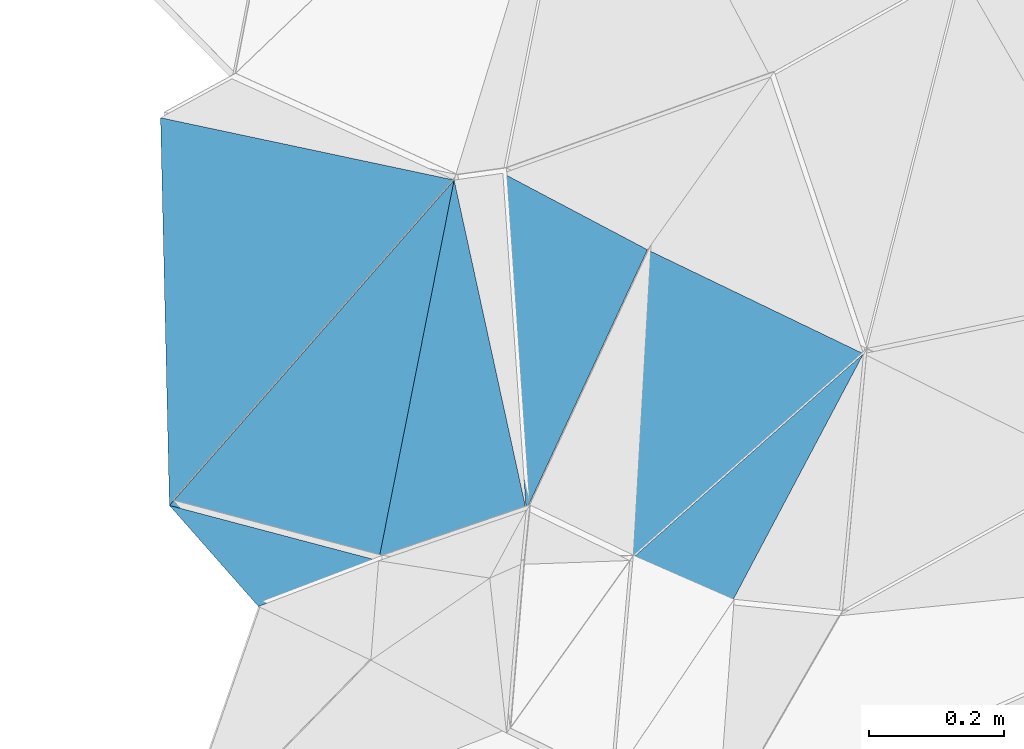
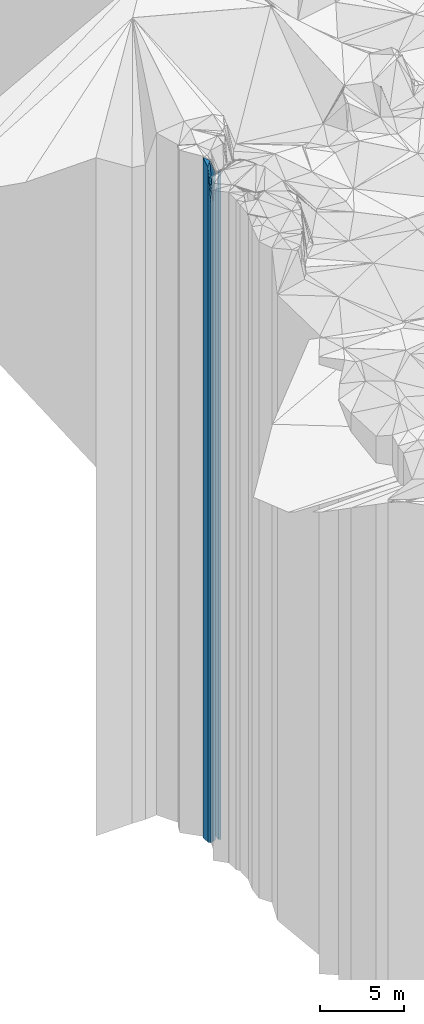
# One storey, part 230 of 275: 7 plates.
"""IFC2X3 building model written with IfcOpenShell, lengths in millimetres."""

import ifcopenshell
import ifcopenshell.guid

model = None  # the IFC model being written
_history = None  # IfcOwnerHistory: only IFC2X3 demands one
_inside = {}  # id of a spatial element -> (the spatial element, [elements in it])
_under = {}  # id of a project, library or spatial element -> (it, [spatial elements below it])
_declared = {}  # id of a project -> (the project, [libraries it declares])
_typed = {}  # id of a type object -> (the type object, [elements of that type])
_made_of = {}  # id of a material, layer set ... -> (it, [elements and type objects made of it])


def new_model(schema):
    """Start an empty IFC model of exactly this schema.

    Asked for "IFC4X3", IfcOpenShell would pick the latest addendum, in which some entities
    have other attributes; the version numbers below select the first issue.
    IFC2X3 requires an IfcOwnerHistory on every rooted entity: one is made here for all.
    """
    global model, _history
    if schema == "IFC4X3":
        model = ifcopenshell.file(schema_version=(4, 3, 0, 0))
    else:
        model = ifcopenshell.file(schema=schema)
    _inside.clear()
    _under.clear()
    _declared.clear()
    _typed.clear()
    _made_of.clear()
    _history = None
    if model.schema == "IFC2X3":
        org = make("IfcOrganization", Name="unknown")
        user = make(
            "IfcPersonAndOrganization",
            ThePerson=make("IfcPerson", FamilyName="unknown"),
            TheOrganization=org,
        )
        app = make(
            "IfcApplication",
            ApplicationDeveloper=org,
            Version="unknown",
            ApplicationFullName="unknown",
            ApplicationIdentifier="unknown",
        )
        _history = make(
            "IfcOwnerHistory",
            OwningUser=user,
            OwningApplication=app,
            ChangeAction="ADDED",
            CreationDate=0,
        )
    return model


def make(cls, **values):
    """One entity of the class cls with the attributes given. An attribute that is None is left unset."""
    return model.create_entity(
        cls, **{name: value for name, value in values.items() if value is not None}
    )


def rooted(cls, **values):
    """An entity with a GlobalId (a new one), such as an element, a storey or a relation."""
    return make(cls, GlobalId=ifcopenshell.guid.new(), OwnerHistory=_history, **values)


def si_unit(unit_type, name, prefix=None):
    """IfcSIUnit, for example si_unit("LENGTHUNIT", "METRE", prefix="MILLI")."""
    return make("IfcSIUnit", UnitType=unit_type, Prefix=prefix, Name=name)


def assignment(units):
    """IfcUnitAssignment: the units of a project."""
    return None if units is None else make("IfcUnitAssignment", Units=units)


def point(xyz):
    """IfcCartesianPoint."""
    return None if xyz is None else make("IfcCartesianPoint", Coordinates=xyz)


def direction(xyz):
    """IfcDirection."""
    return None if xyz is None else make("IfcDirection", DirectionRatios=xyz)


def frame(location, z_axis=None, x_axis=None):
    """IfcAxis2Placement3D, a coordinate frame: its origin and axes. An axis left out is left unset."""
    return make(
        "IfcAxis2Placement3D",
        Location=point(location),
        Axis=direction(z_axis),
        RefDirection=direction(x_axis),
    )


def origin_with_axes():
    """The frame at (0, 0, 0) with the z axis (0, 0, 1) and the x axis (1, 0, 0) written out."""
    return frame((0.0, 0.0, 0.0), z_axis=(0.0, 0.0, 1.0), x_axis=(1.0, 0.0, 0.0))


def place(relative_to, where):
    """IfcLocalPlacement: puts the frame where relative to a parent placement (None: the world)."""
    return make(
        "IfcLocalPlacement", PlacementRelTo=relative_to, RelativePlacement=where
    )


def context(
    kind, dimensions, precision=None, world=None, true_north=None, identifier=None
):
    """IfcGeometricRepresentationContext, for example the 3D "Model" context."""
    return make(
        "IfcGeometricRepresentationContext",
        ContextIdentifier=identifier,
        ContextType=kind,
        CoordinateSpaceDimension=dimensions,
        Precision=precision,
        WorldCoordinateSystem=world,
        TrueNorth=true_north,
    )


def subcontext(parent, identifier, kind, view, scale=None):
    """IfcGeometricRepresentationSubContext, for example "Body" below "Model"."""
    return make(
        "IfcGeometricRepresentationSubContext",
        ContextIdentifier=identifier,
        ContextType=kind,
        ParentContext=parent,
        TargetScale=scale,
        TargetView=view,
    )


def project(units=None, contexts=None):
    """IfcProject with its units and contexts."""
    return rooted(
        "IfcProject",
        Name="project",
        RepresentationContexts=contexts,
        UnitsInContext=assignment(units),
    )


def spatial(cls, under=None, at=None, **own):
    """A site, building, storey or space (cls), placed at a placement, below another one or the project."""
    s = rooted(cls, ObjectPlacement=at, **own)
    if under is not None:
        _under.setdefault(under.id(), (under, []))[1].append(s)
    return s


def faces_of(points, faces, orient=None, outer=None):
    """IfcFace entities. A face is a list of loops; a loop is a list of indices into points, from 0.

    orient and outer hold one flag for each loop. By default every Orientation is true, the
    first loop of a face is its IfcFaceOuterBound and the others are IfcFaceBound.
    """
    made = []
    for i, loops in enumerate(faces):
        bounds = []
        for j, loop in enumerate(loops):
            is_outer = j == 0 if outer is None else outer[i][j]
            bounds.append(
                make(
                    "IfcFaceOuterBound" if is_outer else "IfcFaceBound",
                    Bound=make("IfcPolyLoop", Polygon=[points[k] for k in loop]),
                    Orientation=True if orient is None else orient[i][j],
                )
            )
        made.append(make("IfcFace", Bounds=bounds))
    return made


def faceted_brep(points, faces, orient=None, outer=None, voids=None):
    """IfcFacetedBrep: a solid bounded by flat faces; with voids (closed shells), ...WithVoids."""
    shared = [point(p) for p in points]
    hull = make("IfcClosedShell", CfsFaces=faces_of(shared, faces, orient, outer))
    if voids is None:
        return make("IfcFacetedBrep", Outer=hull)
    return make(
        "IfcFacetedBrepWithVoids",
        Outer=hull,
        Voids=[
            make(cls, CfsFaces=faces_of(shared, fs, o, b)) for cls, fs, o, b in voids
        ],
    )


def shape(context_of_items, identifier, shape_type, items):
    """IfcShapeRepresentation: the items that make up one representation, for example the "Body"."""
    return make(
        "IfcShapeRepresentation",
        ContextOfItems=context_of_items,
        RepresentationIdentifier=identifier,
        RepresentationType=shape_type,
        Items=items,
    )


def material(Name=None, Category=None):
    """IfcMaterial."""
    return make("IfcMaterial", Name=Name, Category=Category)


def made_of(thing, what):
    """Note that an element or type object is made of a material, layer set ...; save() writes the relation."""
    if what is not None:
        _made_of.setdefault(what.id(), (what, []))[1].append(thing)
    return thing


def type_object(cls, material=None, **own):
    """A type object (cls), such as IfcWallType, which elements share."""
    return made_of(rooted(cls, **own), material)


def element(
    cls,
    number,
    at=None,
    inside=None,
    cuts=None,
    type_object=None,
    material=None,
    context=None,
    identifier="Body",
    shape_type=None,
    held_by="IfcProductDefinitionShape",
    body=None,
    shapes=None,
    **own,
):
    """One element of the class cls, such as IfcWall. Its Tag is "e" and its number.

    at: its placement. inside: the storey or other place that contains it. cuts: it is an
    opening in that element (IfcRelVoidsElement). A single representation is given by context,
    identifier, shape_type and body (its items); several are given by shapes. held_by: the class
    of the entity that holds the representations. save() writes the other relations.
    """
    e = rooted(cls, Tag="e%d" % number, ObjectPlacement=at, **own)
    if body is not None:
        shapes = [shape(context, identifier, shape_type, body)]
    if shapes is not None:
        e.Representation = make(held_by, Representations=shapes)
    if inside is not None:
        _inside.setdefault(inside.id(), (inside, []))[1].append(e)
    if cuts is not None:
        rooted(
            "IfcRelVoidsElement", RelatingBuildingElement=cuts, RelatedOpeningElement=e
        )
    if type_object is not None:
        _typed.setdefault(type_object.id(), (type_object, []))[1].append(e)
    return made_of(e, material)


def aggregate(whole, parts):
    """IfcRelAggregates: a whole, such as a stair, and the parts it consists of."""
    return rooted("IfcRelAggregates", RelatingObject=whole, RelatedObjects=parts)


def save(model, path):
    """Write the relations noted so far, then the file.

    IfcRelAggregates (storeys below a building ...), IfcRelContainedInSpatialStructure (elements
    in a storey), IfcRelDefinesByType, IfcRelAssociatesMaterial and IfcRelDeclares: one each for
    every whole, place, type object, material and project.
    """
    for whole, parts in _under.values():
        aggregate(whole, parts)
    for where, things in _inside.values():
        rooted(
            "IfcRelContainedInSpatialStructure",
            RelatedElements=things,
            RelatingStructure=where,
        )
    for kind, things in _typed.values():
        rooted("IfcRelDefinesByType", RelatedObjects=things, RelatingType=kind)
    for what, things in _made_of.values():
        rooted("IfcRelAssociatesMaterial", RelatedObjects=things, RelatingMaterial=what)
    for by, libraries in _declared.values():
        rooted("IfcRelDeclares", RelatingContext=by, RelatedDefinitions=libraries)
    model.write(path)


model = new_model("IFC2X3")

# Units and contexts
model_context = context("Model", 3, precision=1e-05, world=origin_with_axes())
body_context = subcontext(model_context, "Body", "Model", "MODEL_VIEW")
ifc_project = project(units=[si_unit("LENGTHUNIT", "METRE", prefix="MILLI"), si_unit("AREAUNIT", "SQUARE_METRE"), si_unit("VOLUMEUNIT", "CUBIC_METRE"), si_unit("MASSUNIT", "GRAM", prefix="KILO"), si_unit("TIMEUNIT", "SECOND"), si_unit("PLANEANGLEUNIT", "RADIAN"), si_unit("SOLIDANGLEUNIT", "STERADIAN"), si_unit("THERMODYNAMICTEMPERATUREUNIT", "DEGREE_CELSIUS"), si_unit("LUMINOUSINTENSITYUNIT", "LUMEN")], contexts=[model_context])

# Site, building, storey
site_placement = place(None, origin_with_axes())
site = spatial("IfcSite", under=ifc_project, at=site_placement, CompositionType="ELEMENT")
building_placement = place(site_placement, origin_with_axes())
building = spatial("IfcBuilding", under=site, at=building_placement, Name="Undefined", CompositionType="ELEMENT")
storey_placement = place(building_placement, origin_with_axes())
storey = spatial("IfcBuildingStorey", under=building, at=storey_placement, Name="Undefined", CompositionType="ELEMENT", Elevation=0.0)

# Plates
ifc_material = material()
plate_type_1 = type_object("IfcPlateType", PredefinedType="NOTDEFINED")
plate_1_placement = place(storey_placement, frame((-137810.425426011, 92555.7299355465, 31029.0), z_axis=(0.752599852657399, -0.658478140700252, 0.0), x_axis=(-0.658478140700255, -0.752599852657397, 0.0)))
element("IfcPlate", 1, at=plate_1_placement, inside=storey, type_object=plate_type_1, material=ifc_material, Name="00", context=body_context, shape_type="Brep", body=[
    faceted_brep([(-1.09139364212751e-11, -25961.0, 0.0), (497.525970458988, -23201.0, 286.823822021484), (497.525970458988, 23201.0, 286.823822021484), (2.91038304567337e-11, 23201.0, 1.2732925824821e-11), (639.765563964847, -25931.0, 8.73114913702011e-11), (639.765563964847, 23201.0, 8.73114913702011e-11)], [[[0, 1, 2, 3]], [[1, 4, 5, 2]], [[4, 0, 3, 5]], [[5, 3, 2]], [[4, 1, 0]]]),
])
plate_type_2 = type_object("IfcPlateType", PredefinedType="NOTDEFINED")
plate_2_placement = place(storey_placement, frame((-137922.171854982, 91992.4247468501, 31024.0), z_axis=(-0.255555578054144, -0.966794366204837, 0.0), x_axis=(-0.96679436620484, 0.255555578054133, 0.0)))
element("IfcPlate", 2, at=plate_2_placement, inside=storey, type_object=plate_type_2, material=ifc_material, Name="00", context=body_context, shape_type="Brep", body=[
    faceted_brep([(0.0, -23206.0, 1.45519152283669e-11), (154.612030029297, -23196.0, 110.883369445823), (154.612030029297, 23196.0, 110.883369445823), (0.0, 23196.0, 1.45519152283669e-11), (320.156219482393, -25936.0, -2.11002770811319e-10), (320.156219482393, 23196.0, -2.11002770811319e-10)], [[[0, 1, 2, 3]], [[1, 4, 5, 2]], [[4, 0, 3, 5]], [[5, 3, 2]], [[4, 1, 0]]]),
])
plate_type_3 = type_object("IfcPlateType", PredefinedType="NOTDEFINED")
plate_3_placement = place(storey_placement, frame((-137810.425426011, 92555.7299355465, 32394.0), z_axis=(-0.207644558090213, -0.978204343424992, 0.0), x_axis=(-0.978204343424988, 0.207644558090234, 0.0)))
element("IfcPlate", 3, at=plate_3_placement, inside=storey, type_object=plate_type_3, material=ifc_material, Name="00", context=body_context, shape_type="Brep", body=[
    faceted_brep([(2.91038304567337e-11, -24596.0, 0.0), (312.111511230469, -24566.0, 558.46789550782), (312.111511230469, 24566.0, 558.46789550782), (2.91038304567337e-11, 24566.0, 0.0), (444.072052001953, -24936.0, -2.81579559668899e-09), (444.072052001953, 24566.0, -2.81579559668899e-09)], [[[0, 1, 2, 3]], [[1, 4, 5, 2]], [[4, 0, 3, 5]], [[5, 3, 2]], [[4, 1, 0]]]),
])
plate_type_4 = type_object("IfcPlateType", PredefinedType="NOTDEFINED")
plate_4_placement = place(storey_placement, frame((-137703.729639487, 92067.1442121181, 31074.0), z_axis=(-0.90659690263623, 0.421997696830674, 0.0), x_axis=(0.421997696830674, 0.90659690263623, 0.0)))
element("IfcPlate", 4, at=plate_4_placement, inside=storey, type_object=plate_type_4, material=ifc_material, Name="00", context=body_context, shape_type="Brep", body=[
    faceted_brep([(7.27595761418343e-12, -25246.0, 0.0), (437.435211181648, -25886.0, 241.765258789063), (437.435211181648, 23246.0, 241.765258789063), (1.09139364212751e-11, 23246.0, 2.91038304567337e-11), (425.20584106446, -23246.0, -3.95812094211578e-09), (425.20584106446, 23246.0, -3.95812094211578e-09)], [[[0, 1, 2, 3]], [[1, 4, 5, 2]], [[4, 0, 3, 5]], [[5, 3, 2]], [[4, 1, 0]]]),
])
plate_type_5 = type_object("IfcPlateType", PredefinedType="NOTDEFINED")
plate_5_placement = place(storey_placement, frame((-137550.553898395, 91992.7318990184, 31074.0), z_axis=(0.400928765088184, 0.916109232201523, 0.0), x_axis=(0.91610923220154, -0.400928765088145, 0.0)))
element("IfcPlate", 5, at=plate_5_placement, inside=storey, type_object=plate_type_5, material=ifc_material, Name="00", context=body_context, shape_type="Brep", body=[
    faceted_brep([(0.0, -25426.0, 0.0), (194.117263793974, -23246.0, 418.949279785171), (194.117263793974, 23246.0, 418.949279785171), (1.09139364212751e-11, 23246.0, 2.91038304567337e-11), (162.788208007813, -25446.0, 1.70985003933311e-09), (162.788208007813, 23246.0, 1.70985003933311e-09)], [[[0, 1, 2, 3]], [[1, 4, 5, 2]], [[4, 0, 3, 5]], [[5, 3, 2]], [[4, 1, 0]]]),
])
plate_type_6 = type_object("IfcPlateType", PredefinedType="NOTDEFINED")
plate_6_placement = place(storey_placement, frame((-137204.752473843, 92298.7080006626, 31074.0), z_axis=(-0.43398336210372, -0.900920885215318, 0.0), x_axis=(-0.900920885215323, 0.433983362103709, 0.0)))
element("IfcPlate", 6, at=plate_6_placement, inside=storey, type_object=plate_type_6, material=ifc_material, Name="00", context=body_context, shape_type="Brep", body=[
    faceted_brep([(1.09139364212751e-11, -23246.0, 2.91038304567337e-11), (178.751190185518, -25426.0, 425.732330322273), (178.751190185518, 23246.0, 425.732330322273), (1.09139364212751e-11, 23246.0, 2.91038304567337e-11), (354.68295288083, -23246.0, 1.3606040738523e-09), (354.68295288083, 23246.0, 1.3606040738523e-09)], [[[0, 1, 2, 3]], [[1, 4, 5, 2]], [[4, 0, 3, 5]], [[5, 3, 2]], [[4, 1, 0]]]),
])
plate_type_7 = type_object("IfcPlateType", PredefinedType="NOTDEFINED")
plate_7_placement = place(storey_placement, frame((-137922.171854982, 91992.4247468501, 31029.0), z_axis=(-0.323645931047965, 0.946178266140211, 0.0), x_axis=(0.946178266140213, 0.323645931047961, 0.0)))
element("IfcPlate", 7, at=plate_7_placement, inside=storey, type_object=plate_type_7, material=ifc_material, Name="00", context=body_context, shape_type="Brep", body=[
    faceted_brep([(2.91038304567337e-11, -23201.0, 1.2732925824821e-11), (288.043487548828, -25961.0, 496.820861816406), (288.043487548828, 23201.0, 496.820861816406), (2.91038304567337e-11, 23201.0, 1.2732925824821e-11), (230.867935180664, -25291.0, -7.27595761418343e-10), (230.867935180664, 23201.0, -7.27595761418343e-10)], [[[0, 1, 2, 3]], [[1, 4, 5, 2]], [[4, 0, 3, 5]], [[5, 3, 2]], [[4, 1, 0]]]),
])

save(model, "model.ifc")
